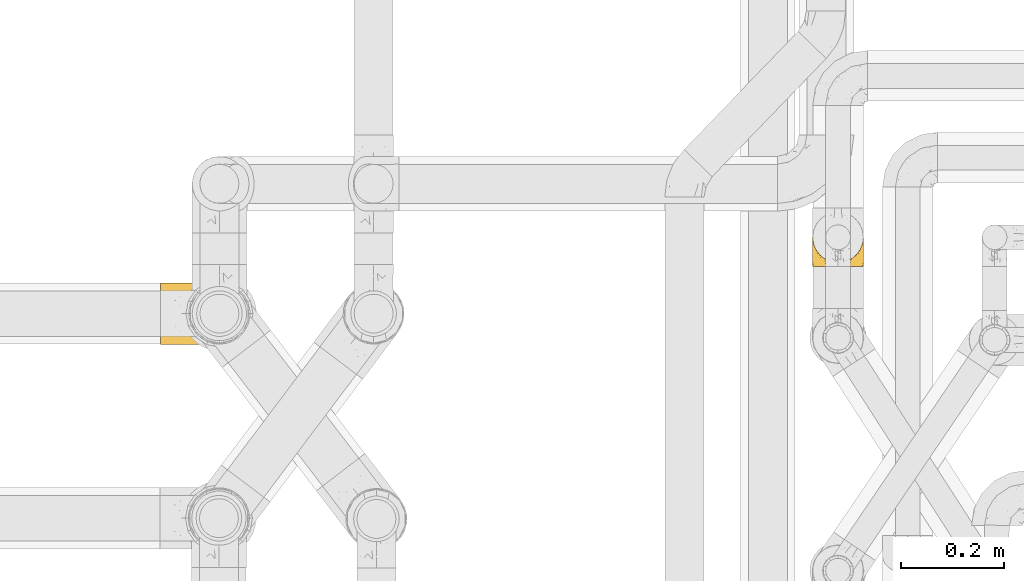
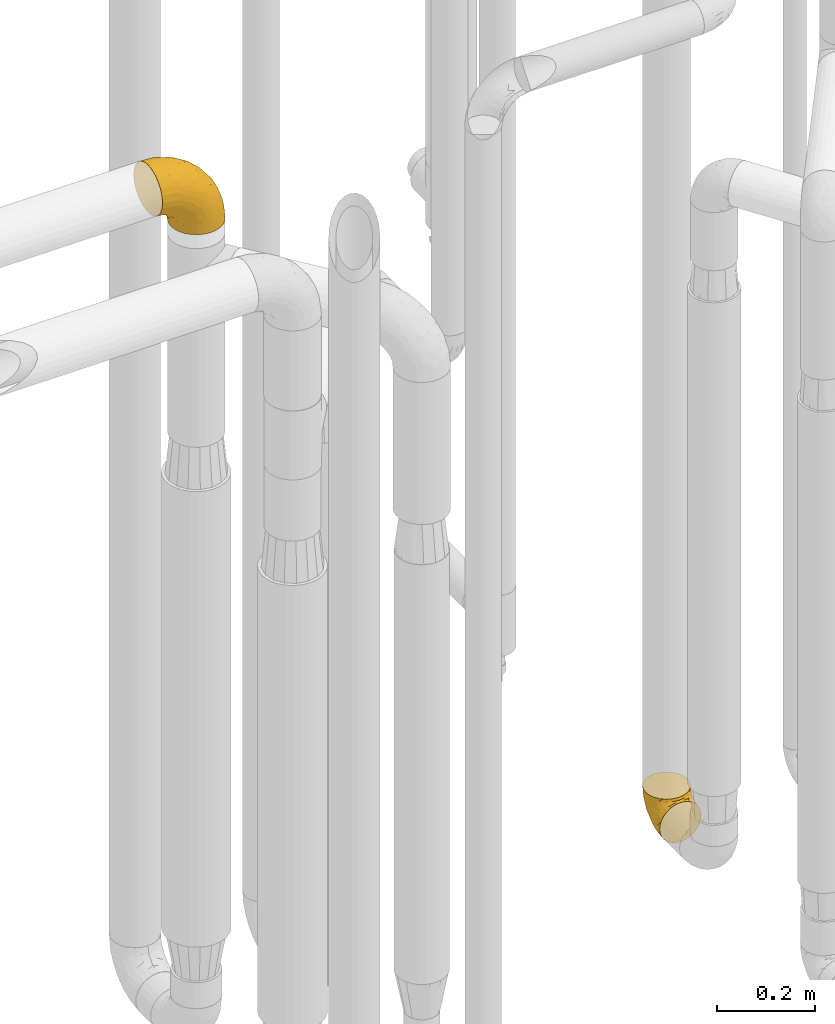
# One storey, part 394 of 827: 2 coverings.
"""IFC2X3 building model written with IfcOpenShell, lengths in millimetres."""

from ifc_helpers import new_model, entity, si_unit, converted_unit, derived_unit, direction, frame, origin, place, context, subcontext, project, spatial, faceted_brep, element, save


model = new_model("IFC2X3")

# Units and contexts
model_context = context("Model", 3, precision=0.01, world=origin(), true_north=direction((6.12303176911189e-17, 1.0)))
body_context = subcontext(model_context, "Body", "Model", "MODEL_VIEW")
ifc_project = project(units=[si_unit("LENGTHUNIT", "METRE", prefix="MILLI"), si_unit("AREAUNIT", "SQUARE_METRE"), si_unit("VOLUMEUNIT", "CUBIC_METRE"), converted_unit("PLANEANGLEUNIT", "DEGREE", entity("IfcRatioMeasure", 0.0174532925199433), si_unit("PLANEANGLEUNIT", "RADIAN"), dimensions=[0, 0, 0, 0, 0, 0, 0]), si_unit("MASSUNIT", "GRAM", prefix="KILO"), derived_unit("MASSDENSITYUNIT", [(si_unit("MASSUNIT", "GRAM", prefix="KILO"), 1), (si_unit("LENGTHUNIT", "METRE"), -3)]), derived_unit("MOMENTOFINERTIAUNIT", [(si_unit("LENGTHUNIT", "METRE"), 4)]), si_unit("TIMEUNIT", "SECOND"), si_unit("FREQUENCYUNIT", "HERTZ"), si_unit("THERMODYNAMICTEMPERATUREUNIT", "DEGREE_CELSIUS"), derived_unit("THERMALTRANSMITTANCEUNIT", [(si_unit("MASSUNIT", "GRAM", prefix="KILO"), 1), (si_unit("THERMODYNAMICTEMPERATUREUNIT", "KELVIN"), -1), (si_unit("TIMEUNIT", "SECOND"), -3)]), derived_unit("VOLUMETRICFLOWRATEUNIT", [(si_unit("LENGTHUNIT", "METRE"), 3), (si_unit("TIMEUNIT", "SECOND"), -1)]), derived_unit("MASSFLOWRATEUNIT", [(si_unit("MASSUNIT", "GRAM", prefix="KILO"), 1), (si_unit("TIMEUNIT", "SECOND"), -1)]), derived_unit("ROTATIONALFREQUENCYUNIT", [(si_unit("TIMEUNIT", "SECOND"), -1)]), si_unit("ELECTRICCURRENTUNIT", "AMPERE"), si_unit("ELECTRICVOLTAGEUNIT", "VOLT"), si_unit("POWERUNIT", "WATT"), si_unit("FORCEUNIT", "NEWTON", prefix="KILO"), si_unit("ILLUMINANCEUNIT", "LUX"), si_unit("LUMINOUSFLUXUNIT", "LUMEN"), si_unit("LUMINOUSINTENSITYUNIT", "CANDELA"), derived_unit("USERDEFINED", [(si_unit("MASSUNIT", "GRAM", prefix="KILO"), -1), (si_unit("LENGTHUNIT", "METRE"), -2), (si_unit("TIMEUNIT", "SECOND"), 3), (si_unit("LUMINOUSFLUXUNIT", "LUMEN"), 1)]), derived_unit("LINEARVELOCITYUNIT", [(si_unit("LENGTHUNIT", "METRE"), 1), (si_unit("TIMEUNIT", "SECOND"), -1)]), si_unit("PRESSUREUNIT", "PASCAL"), derived_unit("USERDEFINED", [(si_unit("LENGTHUNIT", "METRE"), -2), (si_unit("MASSUNIT", "GRAM", prefix="KILO"), 1), (si_unit("TIMEUNIT", "SECOND"), -2)]), derived_unit("LINEARFORCEUNIT", [(si_unit("MASSUNIT", "GRAM", prefix="KILO"), 1), (si_unit("LENGTHUNIT", "METRE"), 1), (si_unit("TIMEUNIT", "SECOND"), -2), (si_unit("LENGTHUNIT", "METRE"), -1)]), derived_unit("PLANARFORCEUNIT", [(si_unit("MASSUNIT", "GRAM", prefix="KILO"), 1), (si_unit("LENGTHUNIT", "METRE"), 1), (si_unit("TIMEUNIT", "SECOND"), -2), (si_unit("LENGTHUNIT", "METRE"), -2)])], contexts=[model_context])

# Site, building, storey
site_placement = place(None, origin())
site = spatial("IfcSite", under=ifc_project, at=site_placement, CompositionType="ELEMENT")
building_placement = place(site_placement, origin())
building = spatial("IfcBuilding", under=site, at=building_placement, CompositionType="ELEMENT")
storey_placement = place(building_placement, frame((0.0, 0.0, 28200.0)))
storey = spatial("IfcBuildingStorey", under=building, at=storey_placement, Name="08", CompositionType="ELEMENT", Elevation=28200.0)

# Coverings
covering_1_placement = place(storey_placement, frame((46642.04, 14375.93, 349.25)))
element("IfcCovering", 1, at=covering_1_placement, inside=storey, Name=":ADSK_", ObjectType=":ADSK_", PredefinedType="INSULATION", context=body_context, shape_type="Brep", body=[
    faceted_brep([(1.6, 1.6, 50.75), (2.83, 1.6, 39.8), (6.47, 1.6, 29.41), (12.32, 1.6, 20.09), (20.11, 1.6, 12.31), (29.43, 1.6, 6.46), (39.81, 1.6, 2.83), (50.75, 1.6, 1.6), (61.69, 1.6, 2.83), (72.08, 1.6, 6.47), (81.4, 1.6, 12.32), (89.18, 1.6, 20.11), (95.03, 1.6, 29.43), (98.66, 1.6, 39.81), (99.9, 1.6, 50.75), (99.25, 1.6, 56.45), (98.66, 1.6, 61.69), (96.84, 1.6, 66.88), (95.02, 1.6, 72.08), (89.17, 1.6, 81.4), (81.38, 1.6, 89.18), (72.06, 1.6, 95.03), (61.68, 1.6, 98.66), (50.75, 1.6, 99.9), (39.8, 1.6, 98.66), (29.41, 1.6, 95.02), (20.09, 1.6, 89.17), (12.31, 1.6, 81.38), (6.46, 1.6, 72.06), (4.64, 1.6, 66.87), (2.83, 1.6, 61.68), (2.24, 1.6, 56.45), (1.92, 1.6, 53.6), (63.47, 11.12, 107.75), (75.32, 16.03, 107.75), (80.41, 19.94, 107.75), (85.5, 23.84, 107.75), (89.4, 28.93, 107.75), (93.31, 34.02, 107.75), (95.77, 39.95, 107.75), (98.22, 45.87, 107.75), (99.14, 52.86, 107.75), (99.52, 55.73, 107.75), (99.9, 58.6, 107.75), (98.22, 71.32, 107.75), (93.31, 83.17, 107.75), (85.5, 93.35, 107.75), (75.32, 101.16, 107.75), (63.47, 106.07, 107.75), (50.75, 107.75, 107.75), (38.02, 106.07, 107.75), (26.17, 101.16, 107.75), (15.99, 93.35, 107.75), (8.18, 83.17, 107.75), (3.27, 71.32, 107.75), (1.6, 58.6, 107.75), (2.35, 52.86, 107.75), (3.27, 45.87, 107.75), (5.73, 39.95, 107.75), (8.18, 34.02, 107.75), (12.09, 28.93, 107.75), (15.99, 23.84, 107.75), (21.08, 19.94, 107.75), (26.17, 16.03, 107.75), (38.02, 11.12, 107.75), (50.75, 9.45, 107.75), (42.18, 81.82, 39.38), (28.42, 84.02, 49.75), (37.78, 93.05, 57.38), (50.75, 102.55, 74.94), (42.85, 104.83, 85.97), (50.75, 105.83, 95.66), (24.75, 91.87, 67.82), (33.81, 101.74, 83.09), (22.57, 97.07, 89.16), (7.18, 38.45, 37.01), (2.73, 22.17, 43.46), (3.09, 42.04, 51.79), (6.92, 77.69, 85.58), (11.58, 75.76, 62.84), (5.17, 62.11, 62.77), (2.71, 66.08, 88.17), (1.6, 54.26, 85.93), (1.6, 55.35, 91.42), (1.6, 56.44, 96.91), (1.6, 56.98, 99.62), (1.6, 57.52, 102.33), (14.18, 87.84, 82.57), (5.88, 19.41, 32.75), (41.06, 48.89, 13.79), (36.25, 26.34, 6.77), (28.62, 44.55, 16.46), (1.6, 23.41, 55.08), (1.6, 28.03, 58.17), (1.6, 32.65, 61.26), (1.6, 37.28, 64.35), (1.6, 41.9, 67.44), (10.85, 20.6, 24.18), (38.35, 63.36, 23.37), (9.6, 62.21, 49.76), (26.24, 19.94, 9.84), (50.75, 13.68, 3.51), (19.31, 80.85, 55.75), (16.41, 66.53, 42.34), (24.56, 71.06, 37.78), (50.75, 63.99, 21.87), (50.75, 75.73, 33.61), (18.47, 26.77, 17.1), (1.6, 4.31, 51.28), (1.6, 7.01, 51.82), (1.6, 12.43, 52.9), (1.6, 17.92, 53.99), (14.36, 43.43, 28.01), (20.64, 56.23, 28.99), (2.32, 54.97, 69.9), (50.75, 34.4, 6.79), (1.6, 44.99, 72.06), (1.6, 48.08, 76.69), (1.6, 51.17, 81.31), (50.75, 87.47, 45.35), (33.88, 74.55, 34.79), (29.24, 60.86, 25.72), (50.75, 49.19, 14.33), (50.75, 95.01, 60.15), (2.8, 10.27, 62.38), (2.48, 48.79, 100.57), (2.7, 45.16, 91.06), (3.2, 44.99, 97.66), (32.98, 6.17, 97.55), (24.67, 7.65, 93.65), (2.95, 21.59, 66.85), (2.19, 19.96, 61.93), (17.92, 21.0, 101.4), (12.02, 27.2, 100.07), (25.73, 14.83, 101.36), (16.63, 19.7, 95.94), (25.6, 10.93, 96.3), (36.72, 9.63, 101.98), (10.66, 19.97, 85.88), (6.87, 21.13, 78.88), (11.12, 14.14, 82.8), (10.31, 30.2, 102.58), (5.94, 36.65, 96.59), (12.84, 8.12, 82.88), (17.38, 9.93, 88.57), (9.74, 24.62, 88.67), (4.63, 11.87, 69.08), (50.75, 7.15, 102.19), (42.52, 5.32, 100.06), (3.12, 26.68, 70.56), (17.58, 13.92, 91.07), (3.97, 30.67, 77.56), (2.73, 42.89, 86.38), (6.23, 34.04, 91.79), (3.45, 36.6, 81.71), (10.84, 26.41, 94.11), (7.98, 10.07, 76.09), (7.33, 15.83, 76.91), (2.39, 41.99, 81.44), (75.76, 14.83, 101.37), (90.65, 26.4, 94.12), (83.57, 21.01, 101.41), (84.85, 19.71, 95.96), (71.05, 5.72, 96.22), (98.54, 21.6, 66.85), (99.3, 19.96, 61.94), (99.9, 28.03, 58.17), (96.86, 11.87, 69.1), (84.1, 9.93, 88.58), (99.9, 58.06, 105.04), (99.9, 56.44, 96.91), (99.9, 57.52, 102.33), (88.63, 8.13, 82.9), (90.36, 14.15, 82.82), (98.29, 44.99, 97.66), (95.55, 36.65, 96.59), (91.18, 30.2, 102.58), (93.49, 10.06, 76.13), (94.15, 15.83, 76.93), (99.01, 48.79, 100.57), (98.76, 42.89, 86.38), (98.85, 45.38, 90.86), (99.9, 12.43, 52.9), (98.69, 10.28, 62.39), (64.78, 9.64, 101.98), (99.9, 55.35, 91.42), (99.9, 54.26, 85.93), (62.91, 6.05, 99.49), (99.9, 7.01, 51.82), (99.9, 9.72, 52.36), (99.9, 32.65, 61.26), (98.37, 26.68, 70.56), (83.9, 13.92, 91.09), (99.9, 37.28, 64.35), (97.51, 30.66, 77.6), (94.62, 21.14, 78.89), (98.04, 36.59, 81.71), (91.73, 24.6, 88.69), (99.9, 17.92, 53.99), (99.9, 23.41, 55.08), (75.87, 10.93, 96.31), (90.83, 19.97, 85.9), (99.1, 41.99, 81.45), (99.9, 48.08, 76.69), (95.26, 34.04, 91.79), (89.47, 27.21, 100.07), (99.9, 51.17, 81.31), (99.9, 44.99, 72.06), (99.9, 41.9, 67.44), (99.09, 55.26, 69.6), (58.64, 104.83, 85.97), (87.31, 87.84, 82.57), (89.93, 75.91, 63.16), (82.22, 80.84, 55.81), (76.74, 91.87, 67.81), (73.12, 83.98, 49.73), (95.54, 19.16, 32.55), (98.7, 22.37, 43.23), (98.79, 66.08, 88.17), (63.71, 93.05, 57.38), (67.68, 101.74, 83.08), (78.92, 97.07, 89.16), (94.57, 77.69, 85.58), (72.88, 44.55, 16.46), (65.25, 26.34, 6.77), (60.44, 48.9, 13.8), (76.94, 70.99, 37.71), (67.61, 74.55, 34.8), (94.38, 37.8, 36.83), (63.11, 63.4, 23.39), (59.31, 81.82, 39.38), (83.03, 26.77, 17.12), (90.66, 20.6, 24.19), (80.8, 56.15, 28.89), (72.22, 60.85, 25.69), (98.39, 42.06, 51.77), (92.31, 57.03, 45.66), (75.27, 19.94, 9.85), (87.15, 43.59, 28.11), (96.03, 62.61, 62.27), (85.1, 66.52, 42.35)], [[[0, 1, 2, 3, 4, 5, 6, 7, 8, 9, 10, 11, 12, 13, 14, 15, 16, 17, 18, 19, 20, 21, 22, 23, 24, 25, 26, 27, 28, 29, 30, 31, 32]], [[33, 34, 35, 36, 37, 38, 39, 40, 41, 42, 43, 44, 45, 46, 47, 48, 49, 50, 51, 52, 53, 54, 55, 56, 57, 58, 59, 60, 61, 62, 63, 64, 65]], [[66, 67, 68]], [[69, 70, 71]], [[68, 72, 73]], [[73, 72, 74]], [[75, 76, 77]], [[78, 79, 80]], [[51, 50, 73]], [[81, 82, 83, 84, 85, 86, 55]], [[52, 87, 53]], [[74, 52, 51]], [[2, 1, 88]], [[89, 90, 91]], [[77, 92, 93, 94, 95, 96]], [[55, 54, 81]], [[78, 53, 87]], [[5, 90, 6]], [[88, 76, 75]], [[97, 3, 2]], [[89, 91, 98]], [[99, 80, 79]], [[90, 5, 100]], [[74, 87, 52]], [[100, 5, 4]], [[90, 101, 6]], [[79, 102, 103]], [[102, 67, 104]], [[105, 98, 106]], [[107, 4, 3]], [[76, 0, 108, 109, 110, 111, 92]], [[107, 112, 113]], [[114, 77, 96]], [[89, 115, 90]], [[114, 96, 116, 117, 118, 82]], [[75, 97, 88]], [[119, 66, 68]], [[50, 71, 70]], [[100, 91, 90]], [[99, 77, 80]], [[102, 104, 103]], [[97, 107, 3]], [[80, 81, 78]], [[107, 97, 112]], [[68, 73, 70]], [[66, 98, 120]], [[78, 81, 54]], [[114, 81, 80]], [[53, 78, 54]], [[78, 87, 79]], [[102, 87, 72]], [[79, 103, 99]], [[4, 107, 100]], [[91, 100, 107]], [[88, 97, 2]], [[112, 97, 75]], [[99, 112, 75]], [[103, 104, 113]], [[91, 121, 98]], [[89, 105, 122, 115]], [[101, 90, 115]], [[101, 7, 6]], [[88, 1, 76]], [[0, 76, 1]], [[92, 77, 76]], [[73, 74, 51]], [[87, 74, 72]], [[81, 114, 82]], [[77, 114, 80]], [[87, 102, 79]], [[67, 102, 72]], [[68, 67, 72]], [[67, 120, 104]], [[120, 121, 104]], [[104, 121, 113]], [[121, 120, 98]], [[91, 107, 113]], [[91, 113, 121]], [[103, 113, 112]], [[106, 98, 66]], [[105, 89, 98]], [[106, 66, 119]], [[67, 66, 120]], [[68, 69, 123, 119]], [[50, 49, 71]], [[50, 70, 73]], [[112, 99, 103]], [[77, 99, 75]], [[69, 68, 70]], [[29, 124, 110]], [[84, 83, 125]], [[126, 82, 118]], [[59, 58, 127]], [[25, 128, 129]], [[130, 93, 131]], [[132, 62, 133]], [[134, 135, 136]], [[137, 65, 64]], [[64, 134, 137]], [[138, 139, 140]], [[111, 110, 124, 92]], [[134, 136, 137]], [[134, 64, 63]], [[141, 60, 142]], [[125, 58, 57]], [[143, 144, 140]], [[143, 26, 144]], [[127, 83, 82]], [[28, 124, 29]], [[108, 0, 32, 31, 30, 110, 109]], [[30, 29, 110]], [[135, 145, 138]], [[28, 146, 124]], [[57, 56, 55, 86, 85, 84]], [[147, 148, 23]], [[24, 23, 148]], [[25, 144, 26]], [[95, 94, 149]], [[24, 128, 25]], [[150, 138, 144]], [[124, 146, 131]], [[127, 58, 125]], [[151, 149, 139]], [[127, 126, 142]], [[142, 59, 127]], [[152, 142, 126]], [[153, 154, 155]], [[153, 133, 141]], [[146, 28, 27]], [[143, 156, 27]], [[157, 149, 130]], [[61, 133, 62]], [[134, 132, 135]], [[148, 128, 24]], [[65, 137, 147]], [[147, 137, 148]], [[128, 137, 136]], [[137, 128, 148]], [[128, 136, 129]], [[150, 129, 136]], [[25, 129, 144]], [[158, 152, 117]], [[152, 118, 117]], [[153, 142, 152]], [[158, 116, 154]], [[145, 151, 138]], [[153, 152, 158]], [[133, 153, 155]], [[133, 155, 132]], [[153, 141, 142]], [[135, 132, 155]], [[134, 63, 132]], [[145, 135, 155]], [[135, 138, 150]], [[155, 154, 145]], [[151, 154, 96]], [[154, 151, 145]], [[149, 94, 130]], [[82, 126, 127]], [[118, 152, 126]], [[151, 96, 95]], [[139, 149, 157]], [[151, 95, 149]], [[93, 92, 131]], [[130, 146, 156]], [[130, 94, 93]], [[84, 125, 57]], [[127, 125, 83]], [[140, 139, 157]], [[151, 139, 138]], [[140, 157, 143]], [[138, 140, 144]], [[156, 143, 157]], [[27, 26, 143]], [[130, 156, 157]], [[146, 27, 156]], [[132, 63, 62]], [[124, 131, 92]], [[130, 131, 146]], [[129, 150, 144]], [[135, 150, 136]], [[60, 141, 61]], [[60, 59, 142]], [[133, 61, 141]], [[116, 96, 154]], [[153, 158, 154]], [[158, 117, 116]], [[34, 33, 159]], [[160, 161, 162]], [[22, 21, 163]], [[164, 165, 166]], [[19, 18, 167]], [[168, 21, 20]], [[169, 43, 42, 41, 40, 170, 171]], [[172, 173, 168]], [[174, 38, 175]], [[176, 37, 36]], [[177, 164, 178]], [[40, 179, 170]], [[180, 181, 175]], [[17, 182, 183]], [[65, 147, 184]], [[185, 174, 186]], [[23, 22, 187]], [[174, 39, 38]], [[15, 14, 188, 189, 182, 16]], [[179, 40, 39]], [[190, 191, 164]], [[192, 163, 168]], [[33, 184, 159]], [[178, 173, 172]], [[193, 194, 191]], [[18, 183, 167]], [[173, 178, 195]], [[196, 197, 194]], [[198, 199, 183, 182]], [[182, 17, 16]], [[18, 17, 183]], [[200, 159, 184]], [[192, 168, 201]], [[187, 163, 200]], [[202, 203, 180]], [[185, 179, 174]], [[160, 204, 205]], [[206, 181, 180]], [[206, 180, 203]], [[199, 165, 183]], [[165, 164, 167]], [[172, 177, 178]], [[200, 192, 162]], [[205, 161, 160]], [[65, 184, 33]], [[163, 187, 22]], [[175, 204, 180]], [[174, 181, 186]], [[204, 196, 202]], [[197, 160, 162]], [[196, 207, 202]], [[205, 204, 176]], [[196, 204, 160]], [[176, 204, 175]], [[205, 35, 161]], [[34, 159, 161]], [[162, 161, 159]], [[200, 162, 159]], [[197, 162, 201]], [[194, 197, 201]], [[196, 160, 197]], [[191, 195, 178]], [[208, 196, 194]], [[186, 181, 206]], [[175, 181, 174]], [[191, 190, 193]], [[193, 208, 194]], [[195, 194, 201]], [[178, 164, 191]], [[168, 163, 21]], [[166, 165, 199]], [[166, 190, 164]], [[187, 200, 184]], [[184, 147, 187]], [[23, 187, 147]], [[174, 179, 39]], [[170, 179, 185]], [[194, 195, 191]], [[173, 201, 168]], [[201, 173, 195]], [[172, 168, 20]], [[20, 19, 172]], [[177, 172, 19]], [[19, 167, 177]], [[164, 177, 167]], [[35, 205, 36]], [[35, 34, 161]], [[183, 165, 167]], [[162, 192, 201]], [[163, 192, 200]], [[175, 38, 37]], [[205, 176, 36]], [[175, 37, 176]], [[204, 202, 180]], [[207, 196, 208]], [[207, 203, 202]], [[209, 186, 206, 203, 207, 208]], [[48, 210, 71]], [[211, 212, 213]], [[214, 213, 215]], [[216, 217, 13]], [[218, 43, 169, 171, 170, 185, 186]], [[219, 220, 214]], [[47, 46, 221]], [[210, 48, 220]], [[211, 222, 212]], [[222, 45, 44]], [[221, 220, 47]], [[47, 220, 48]], [[221, 211, 214]], [[223, 224, 225]], [[211, 46, 45]], [[226, 227, 215]], [[43, 218, 44]], [[217, 216, 228]], [[227, 229, 230]], [[14, 13, 217]], [[224, 9, 8]], [[10, 231, 11]], [[11, 232, 12]], [[233, 223, 234]], [[235, 208, 193, 190, 166, 199]], [[236, 235, 228]], [[222, 44, 218]], [[106, 230, 229]], [[224, 237, 9]], [[232, 238, 228]], [[9, 237, 10]], [[115, 224, 101]], [[239, 235, 236]], [[232, 11, 231]], [[223, 231, 237]], [[224, 8, 101]], [[223, 229, 234]], [[225, 115, 122, 105]], [[216, 12, 232]], [[209, 235, 239]], [[210, 219, 69]], [[219, 214, 215]], [[230, 119, 219]], [[209, 218, 186]], [[239, 212, 222]], [[239, 222, 218]], [[45, 222, 211]], [[236, 212, 239]], [[213, 212, 240]], [[223, 237, 224]], [[231, 10, 237]], [[238, 232, 231]], [[216, 232, 228]], [[233, 231, 223]], [[236, 238, 240]], [[115, 225, 224]], [[234, 229, 227]], [[8, 7, 101]], [[235, 209, 208]], [[218, 209, 239]], [[217, 228, 235]], [[13, 12, 216]], [[235, 199, 217]], [[217, 199, 198, 182, 189, 188, 14]], [[211, 221, 46]], [[220, 221, 214]], [[71, 210, 69]], [[71, 49, 48]], [[219, 210, 220]], [[226, 215, 213]], [[211, 213, 214]], [[226, 213, 240]], [[215, 227, 230]], [[233, 240, 238]], [[234, 227, 226]], [[233, 234, 226]], [[229, 223, 225]], [[240, 233, 226]], [[233, 238, 231]], [[225, 105, 229]], [[229, 105, 106]], [[106, 119, 230]], [[123, 69, 219, 119]], [[215, 230, 219]], [[238, 236, 228]], [[212, 236, 240]]]),
])
covering_2_placement = place(storey_placement, frame((45378.63, 14225.57, 2384.4)))
element("IfcCovering", 2, at=covering_2_placement, inside=storey, Name=":ADSK_", ObjectType=":ADSK_", PredefinedType="INSULATION", context=body_context, shape_type="Brep", body=[
    faceted_brep([(128.83, 119.0, 1.6), (141.39, 114.61, 1.6), (152.67, 107.52, 1.6), (162.08, 98.11, 1.6), (169.16, 86.83, 1.6), (173.56, 74.26, 1.6), (175.05, 61.05, 1.6), (173.55, 47.81, 1.6), (169.16, 35.25, 1.6), (162.07, 23.97, 1.6), (152.66, 14.56, 1.6), (141.38, 7.48, 1.6), (128.81, 3.08, 1.6), (115.6, 1.6, 1.6), (102.36, 3.09, 1.6), (89.8, 7.48, 1.6), (78.52, 14.57, 1.6), (69.11, 23.99, 1.6), (62.03, 35.26, 1.6), (57.63, 47.83, 1.6), (56.15, 61.05, 1.6), (57.64, 74.28, 1.6), (62.03, 86.84, 1.6), (69.12, 98.12, 1.6), (78.54, 107.53, 1.6), (89.81, 114.61, 1.6), (102.38, 119.01, 1.6), (115.6, 120.5, 1.6), (1.6, 45.66, 58.17), (1.6, 31.32, 64.11), (1.6, 19.01, 73.56), (1.6, 9.56, 85.87), (1.6, 3.62, 100.21), (1.6, 1.6, 115.6), (1.6, 3.62, 130.98), (1.6, 9.56, 145.32), (1.6, 19.01, 157.63), (1.6, 31.32, 167.08), (1.6, 45.66, 173.02), (1.6, 61.05, 175.05), (1.6, 76.43, 173.02), (1.6, 90.77, 167.08), (1.6, 103.08, 157.63), (1.6, 112.53, 145.32), (1.6, 118.47, 130.98), (1.6, 120.5, 115.6), (1.6, 118.47, 100.21), (1.6, 112.53, 85.87), (1.6, 103.08, 73.56), (1.6, 90.77, 64.11), (1.6, 76.43, 58.17), (1.6, 61.05, 56.15), (32.35, 95.74, 160.93), (43.24, 82.17, 165.97), (67.79, 93.88, 151.16), (39.06, 71.8, 169.95), (46.49, 61.05, 169.14), (143.21, 109.14, 47.74), (128.0, 108.65, 81.62), (144.51, 100.7, 69.65), (104.87, 79.94, 137.09), (88.32, 61.05, 151.81), (124.24, 61.05, 124.24), (70.72, 115.7, 120.32), (48.42, 112.92, 136.76), (74.22, 110.7, 129.05), (37.66, 117.93, 127.83), (61.68, 119.47, 111.19), (151.61, 89.21, 73.49), (162.2, 91.01, 40.92), (73.52, 83.0, 154.8), (66.93, 71.74, 161.22), (43.54, 106.1, 148.51), (169.14, 61.05, 46.49), (166.98, 79.17, 43.55), (137.86, 76.32, 105.65), (156.83, 73.8, 75.81), (103.08, 112.99, 102.22), (111.05, 104.29, 111.05), (122.98, 119.46, 31.64), (111.19, 119.47, 61.68), (120.32, 115.7, 70.72), (68.6, 120.5, 93.82), (52.71, 120.5, 101.92), (36.82, 120.5, 110.02), (151.81, 61.05, 88.32), (134.29, 115.97, 34.61), (155.8, 101.43, 34.27), (102.22, 94.14, 130.32), (130.43, 94.58, 101.6), (80.3, 104.07, 135.16), (92.65, 118.63, 92.65), (93.82, 120.5, 68.6), (81.21, 120.5, 81.21), (113.28, 120.5, 16.21), (110.02, 120.5, 36.82), (101.92, 120.5, 52.71), (16.21, 120.5, 113.28), (84.67, 117.67, 49.51), (87.66, 114.99, 24.29), (74.04, 109.18, 33.37), (21.09, 118.26, 97.47), (35.03, 117.87, 92.13), (52.93, 111.2, 65.64), (39.76, 103.41, 63.0), (34.91, 108.57, 72.44), (67.69, 112.76, 54.52), (44.31, 75.65, 38.38), (44.87, 89.98, 46.09), (54.18, 85.51, 30.11), (51.99, 61.05, 22.47), (53.35, 73.87, 22.86), (18.29, 111.26, 82.06), (23.44, 101.69, 68.74), (28.92, 88.74, 56.57), (13.79, 86.0, 60.39), (18.1, 74.52, 55.21), (32.62, 70.92, 47.46), (22.47, 61.05, 51.99), (100.59, 118.96, 19.27), (78.3, 119.01, 66.98), (62.67, 117.67, 75.5), (58.76, 82.93, 15.03), (64.93, 96.71, 21.65), (56.12, 96.25, 38.96), (75.28, 106.01, 16.17), (97.34, 119.26, 36.61), (64.0, 105.56, 42.47), (40.17, 61.05, 40.17), (38.41, 114.42, 81.33), (51.71, 119.14, 89.72), (52.67, 102.94, 52.09), (39.74, 18.7, 62.98), (52.66, 19.16, 52.08), (52.9, 10.9, 65.65), (27.75, 5.81, 89.82), (51.71, 2.95, 89.72), (38.57, 2.72, 97.2), (44.33, 46.46, 38.35), (67.68, 9.34, 54.51), (93.82, 1.6, 68.6), (81.21, 1.6, 81.21), (78.3, 3.08, 66.99), (18.1, 47.58, 55.21), (87.65, 7.11, 24.29), (13.78, 36.09, 60.39), (75.27, 16.09, 16.17), (64.92, 25.4, 21.63), (21.09, 3.83, 97.47), (16.21, 1.6, 113.28), (62.67, 4.42, 75.5), (23.43, 20.4, 68.74), (32.63, 51.15, 47.46), (18.29, 10.83, 82.06), (63.99, 16.53, 42.47), (56.13, 25.84, 38.93), (53.35, 48.24, 22.84), (110.02, 1.6, 36.82), (101.92, 1.6, 52.71), (97.32, 2.83, 36.62), (113.28, 1.6, 16.21), (54.19, 36.6, 30.08), (58.76, 39.17, 15.02), (44.88, 32.11, 46.08), (28.91, 33.35, 56.57), (52.71, 1.6, 101.92), (84.65, 4.42, 49.52), (74.03, 12.92, 33.36), (100.57, 3.14, 19.28), (34.93, 13.52, 72.43), (68.6, 1.6, 93.82), (36.82, 1.6, 110.02), (38.41, 7.67, 81.33), (67.79, 28.21, 151.16), (32.35, 26.35, 160.93), (43.54, 15.99, 148.51), (48.42, 9.17, 136.76), (39.06, 50.29, 169.95), (43.24, 39.92, 165.97), (66.93, 50.35, 161.22), (61.68, 2.62, 111.19), (120.32, 6.39, 70.72), (122.97, 2.63, 31.66), (134.28, 6.11, 34.61), (111.05, 17.8, 111.05), (128.03, 13.43, 81.57), (130.43, 27.5, 101.58), (111.19, 2.62, 61.68), (92.65, 3.46, 92.65), (37.66, 4.16, 127.83), (73.52, 39.09, 154.8), (144.5, 21.38, 69.65), (155.79, 20.65, 34.27), (151.61, 32.87, 73.47), (164.01, 31.06, 32.52), (137.86, 45.77, 105.65), (104.87, 42.15, 137.09), (143.2, 12.94, 47.72), (74.22, 11.39, 129.05), (103.12, 9.11, 102.2), (166.97, 42.91, 43.54), (80.3, 18.03, 135.17), (102.23, 27.95, 130.32), (155.79, 45.01, 76.08), (70.72, 6.39, 120.32)], [[[0, 1, 2, 3, 4, 5, 6, 7, 8, 9, 10, 11, 12, 13, 14, 15, 16, 17, 18, 19, 20, 21, 22, 23, 24, 25, 26, 27]], [[28, 29, 30, 31, 32, 33, 34, 35, 36, 37, 38, 39, 40, 41, 42, 43, 44, 45, 46, 47, 48, 49, 50, 51]], [[52, 53, 54]], [[55, 39, 56]], [[57, 58, 59]], [[60, 61, 62]], [[63, 64, 65]], [[66, 63, 67]], [[59, 68, 69]], [[53, 70, 54]], [[41, 40, 53]], [[53, 71, 70]], [[72, 42, 52]], [[42, 41, 52]], [[73, 5, 74]], [[68, 75, 76]], [[43, 72, 64]], [[45, 44, 66]], [[58, 77, 78]], [[79, 80, 81]], [[67, 82, 83, 84]], [[75, 62, 85]], [[1, 0, 86]], [[2, 87, 3]], [[57, 87, 2]], [[42, 72, 43]], [[5, 4, 74]], [[2, 1, 57]], [[69, 3, 87]], [[5, 73, 6]], [[59, 87, 57]], [[66, 64, 63]], [[88, 89, 78]], [[54, 88, 90]], [[75, 60, 62]], [[91, 92, 93, 82]], [[79, 27, 94, 95]], [[76, 73, 74]], [[80, 95, 96, 92]], [[57, 1, 86]], [[56, 71, 55]], [[77, 91, 63]], [[80, 91, 81]], [[67, 91, 82]], [[71, 56, 61]], [[69, 4, 3]], [[74, 69, 68]], [[75, 89, 60]], [[80, 79, 95]], [[81, 57, 86]], [[76, 75, 85]], [[89, 68, 59]], [[58, 57, 81]], [[59, 58, 89]], [[90, 88, 78]], [[75, 68, 89]], [[70, 88, 54]], [[60, 89, 88]], [[77, 58, 81]], [[89, 58, 78]], [[91, 77, 81]], [[77, 63, 65]], [[78, 77, 65]], [[54, 90, 72]], [[91, 80, 92]], [[79, 81, 86]], [[86, 0, 79]], [[27, 79, 0]], [[66, 84, 97, 45]], [[91, 67, 63]], [[84, 66, 67]], [[64, 44, 43]], [[64, 66, 44]], [[65, 72, 90]], [[53, 52, 41]], [[72, 52, 54]], [[72, 65, 64]], [[65, 90, 78]], [[60, 71, 61]], [[55, 71, 53]], [[71, 60, 70]], [[88, 70, 60]], [[53, 40, 55]], [[39, 55, 40]], [[4, 69, 74]], [[59, 69, 87]], [[73, 76, 85]], [[68, 76, 74]], [[98, 99, 100]], [[84, 101, 97]], [[84, 83, 102]], [[97, 101, 46]], [[103, 104, 105]], [[47, 46, 101]], [[106, 98, 100]], [[107, 108, 109]], [[110, 107, 111]], [[112, 48, 47]], [[48, 113, 49]], [[113, 114, 115]], [[116, 51, 50]], [[115, 50, 49]], [[116, 117, 118]], [[119, 95, 94]], [[111, 107, 109]], [[93, 120, 121]], [[122, 123, 22]], [[121, 106, 103]], [[25, 24, 99]], [[114, 113, 104]], [[124, 109, 108]], [[25, 119, 26]], [[27, 26, 94]], [[112, 113, 48]], [[125, 123, 100]], [[24, 125, 99]], [[111, 20, 110]], [[109, 122, 111]], [[119, 94, 26]], [[99, 126, 119]], [[123, 124, 127]], [[117, 107, 128]], [[122, 22, 21]], [[129, 130, 121]], [[123, 23, 22]], [[92, 98, 120]], [[127, 106, 100]], [[23, 125, 24]], [[93, 121, 82]], [[119, 126, 95]], [[21, 20, 111]], [[123, 122, 109]], [[21, 111, 122]], [[107, 110, 128]], [[117, 128, 118]], [[107, 117, 108]], [[104, 108, 114]], [[124, 108, 131]], [[25, 99, 119]], [[96, 126, 98]], [[98, 92, 96]], [[123, 125, 23]], [[99, 125, 100]], [[103, 106, 131]], [[120, 106, 121]], [[83, 82, 130]], [[101, 102, 112]], [[130, 102, 83]], [[121, 130, 82]], [[102, 130, 129]], [[101, 112, 47]], [[112, 129, 105]], [[118, 51, 116]], [[108, 117, 114]], [[115, 116, 50]], [[114, 117, 116]], [[112, 102, 129]], [[102, 101, 84]], [[104, 103, 131]], [[129, 121, 103]], [[104, 131, 108]], [[105, 104, 113]], [[112, 105, 113]], [[103, 105, 129]], [[127, 124, 131]], [[123, 109, 124]], [[106, 127, 131]], [[123, 127, 100]], [[98, 126, 99]], [[95, 126, 96]], [[113, 115, 49]], [[116, 115, 114]], [[46, 45, 97]], [[92, 120, 93]], [[106, 120, 98]], [[132, 133, 134]], [[135, 136, 137]], [[110, 138, 128]], [[139, 134, 133]], [[140, 141, 142]], [[143, 51, 118]], [[16, 15, 144]], [[28, 145, 29]], [[146, 147, 17]], [[144, 146, 16]], [[31, 148, 32]], [[148, 149, 32]], [[139, 142, 150]], [[30, 29, 151]], [[152, 143, 118]], [[31, 30, 153]], [[139, 133, 154]], [[155, 154, 133]], [[110, 156, 138]], [[142, 141, 150]], [[20, 19, 156]], [[157, 158, 159]], [[14, 13, 160]], [[17, 16, 146]], [[161, 162, 147]], [[18, 162, 19]], [[152, 163, 164]], [[137, 136, 165]], [[144, 166, 167]], [[133, 163, 155]], [[144, 167, 146]], [[147, 18, 17]], [[29, 145, 151]], [[128, 138, 152]], [[160, 157, 168]], [[160, 168, 14]], [[14, 168, 15]], [[167, 166, 139]], [[151, 169, 153]], [[162, 156, 19]], [[141, 170, 150]], [[164, 163, 132]], [[147, 162, 18]], [[156, 162, 161]], [[156, 161, 138]], [[156, 110, 20]], [[163, 138, 161]], [[128, 152, 118]], [[155, 163, 161]], [[132, 163, 133]], [[159, 166, 144]], [[144, 15, 168]], [[166, 158, 140]], [[168, 159, 144]], [[147, 146, 167]], [[142, 139, 166]], [[134, 139, 150]], [[135, 31, 153]], [[136, 170, 165]], [[136, 150, 170]], [[148, 137, 171]], [[150, 136, 172]], [[151, 153, 30]], [[136, 135, 172]], [[163, 152, 138]], [[143, 28, 51]], [[152, 164, 143]], [[145, 143, 164]], [[171, 137, 165]], [[137, 148, 135]], [[31, 135, 148]], [[172, 135, 153]], [[150, 172, 134]], [[132, 169, 151]], [[169, 134, 172]], [[164, 132, 151]], [[134, 169, 132]], [[153, 169, 172]], [[161, 147, 155]], [[154, 147, 167]], [[147, 154, 155]], [[139, 154, 167]], [[157, 159, 168]], [[166, 159, 158]], [[143, 145, 28]], [[151, 145, 164]], [[149, 148, 171]], [[149, 33, 32]], [[140, 142, 166]], [[173, 174, 175]], [[35, 34, 176]], [[177, 178, 179]], [[180, 171, 165, 170]], [[181, 182, 183]], [[184, 185, 186]], [[187, 188, 140]], [[189, 33, 149, 171]], [[178, 190, 179]], [[34, 189, 176]], [[39, 38, 177]], [[191, 192, 193]], [[9, 8, 194]], [[174, 178, 37]], [[38, 37, 178]], [[35, 175, 36]], [[195, 62, 196]], [[180, 189, 171]], [[37, 36, 174]], [[183, 11, 197]], [[188, 170, 141, 140]], [[184, 198, 199]], [[8, 7, 200]], [[201, 184, 202]], [[13, 12, 182]], [[181, 185, 199]], [[183, 12, 11]], [[62, 195, 85]], [[202, 184, 186]], [[10, 197, 11]], [[199, 188, 181]], [[194, 8, 200]], [[203, 195, 193]], [[62, 61, 196]], [[197, 191, 185]], [[10, 192, 197]], [[7, 6, 73]], [[197, 192, 191]], [[192, 10, 9]], [[193, 192, 194]], [[7, 73, 200]], [[179, 61, 56]], [[203, 73, 85]], [[187, 140, 158, 157]], [[180, 188, 204]], [[179, 196, 61]], [[197, 181, 183]], [[181, 187, 182]], [[201, 173, 175]], [[203, 193, 200]], [[186, 191, 193]], [[197, 185, 181]], [[193, 195, 186]], [[196, 186, 195]], [[186, 196, 202]], [[190, 202, 196]], [[186, 185, 191]], [[199, 185, 184]], [[198, 184, 201]], [[188, 199, 204]], [[173, 201, 202]], [[175, 176, 198]], [[188, 180, 170]], [[189, 180, 204]], [[189, 204, 176]], [[189, 34, 33]], [[187, 157, 182]], [[188, 187, 181]], [[182, 157, 160, 13]], [[12, 183, 182]], [[198, 176, 204]], [[35, 176, 175]], [[175, 174, 36]], [[178, 174, 173]], [[199, 198, 204]], [[175, 198, 201]], [[177, 179, 56]], [[178, 173, 190]], [[202, 190, 173]], [[196, 179, 190]], [[39, 177, 56]], [[38, 178, 177]], [[193, 194, 200]], [[9, 194, 192]], [[73, 203, 200]], [[85, 195, 203]]]),
])

save(model, "model.ifc")
